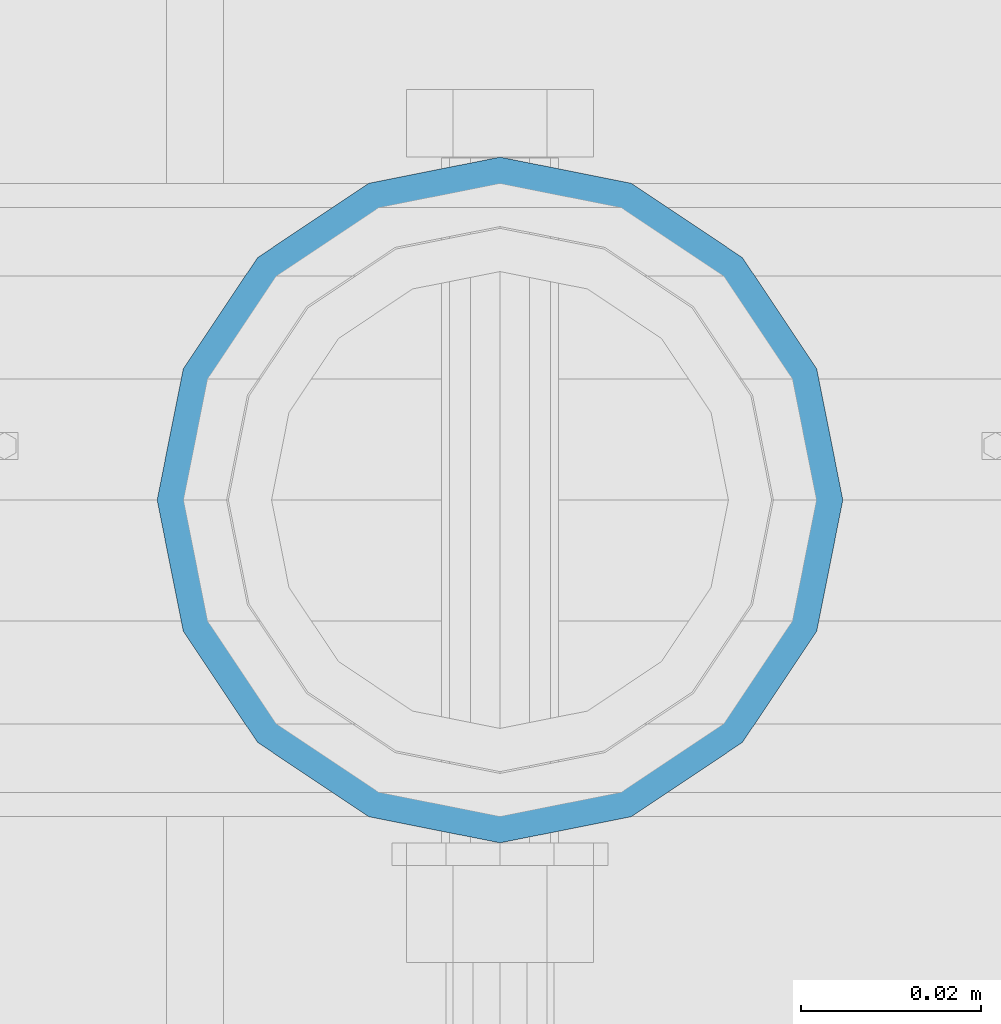
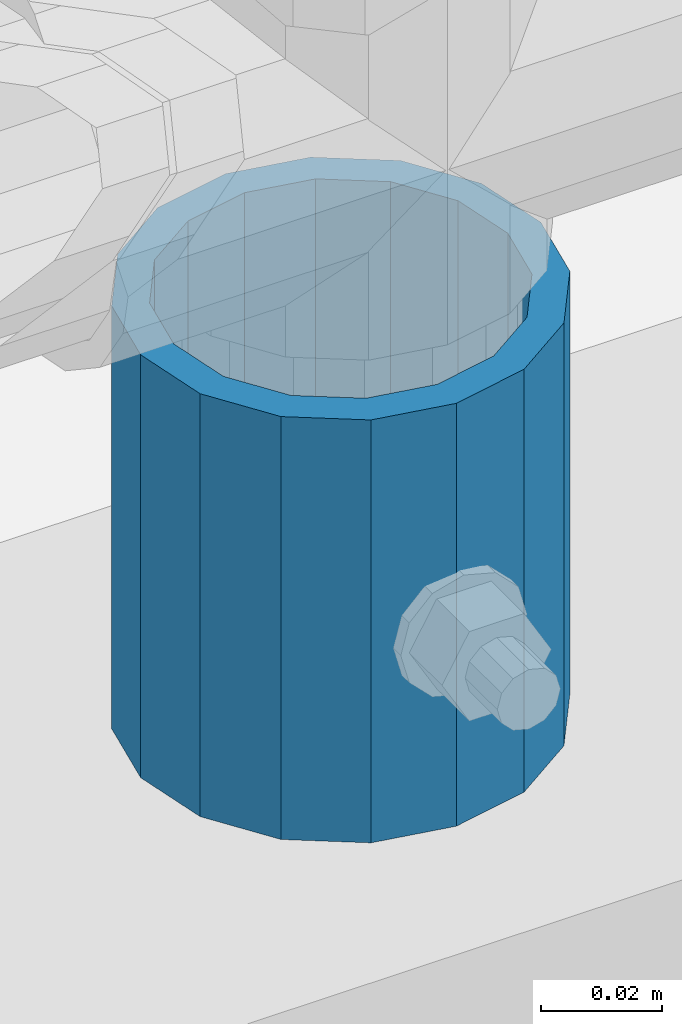
# One storey, part 69 of 242: 1 column.
"""IFC2X3 building model written with IfcOpenShell, lengths in millimetres."""

from ifc_helpers import new_model, si_unit, frame, origin_with_axes, place, context, subcontext, project, spatial, faceted_brep, material, type_object, element, save


model = new_model("IFC2X3")

# Units and contexts
model_context = context("Model", 3, precision=1e-05, world=origin_with_axes())
body_context = subcontext(model_context, "Body", "Model", "MODEL_VIEW")
ifc_project = project(units=[si_unit("LENGTHUNIT", "METRE", prefix="MILLI"), si_unit("AREAUNIT", "SQUARE_METRE"), si_unit("VOLUMEUNIT", "CUBIC_METRE"), si_unit("MASSUNIT", "GRAM", prefix="KILO"), si_unit("TIMEUNIT", "SECOND"), si_unit("PLANEANGLEUNIT", "RADIAN"), si_unit("SOLIDANGLEUNIT", "STERADIAN"), si_unit("THERMODYNAMICTEMPERATUREUNIT", "DEGREE_CELSIUS"), si_unit("LUMINOUSINTENSITYUNIT", "LUMEN")], contexts=[model_context])

# Site, building, storey
site_placement = place(None, origin_with_axes())
site = spatial("IfcSite", under=ifc_project, at=site_placement, CompositionType="ELEMENT")
building_placement = place(site_placement, origin_with_axes())
building = spatial("IfcBuilding", under=site, at=building_placement, Name="Standard", CompositionType="ELEMENT")
storey_placement = place(building_placement, origin_with_axes())
storey = spatial("IfcBuildingStorey", under=building, at=storey_placement, Name="Undefined", CompositionType="ELEMENT", Elevation=0.0)

# Column
ifc_material = material()
column_type = type_object("IfcColumnType", PredefinedType="NOTDEFINED")
column_placement = place(storey_placement, frame((-38563.0, -19335.5, 168.02), z_axis=(0.0, 1.0, 0.0), x_axis=(0.0, 0.0, 1.0)))
element("IfcColumn", 1, at=column_placement, inside=storey, type_object=column_type, material=ifc_material, context=body_context, shape_type="Brep", body=[
    faceted_brep([(0.0, -31.75, 0.0), (0.0, -29.3331751572332, 12.1501989775934), (85.0, -29.3331751572332, 12.1501989775934), (85.0, -31.75, 0.0), (0.0, -22.4506403026717, 22.4506403026717), (85.0, -22.4506403026717, 22.4506403026717), (0.0, -12.1501989775934, 29.3331751572332), (85.0, -12.1501989775934, 29.3331751572332), (0.0, 0.0, 31.75), (85.0, 0.0, 31.75), (0.0, 12.1501989775934, 29.3331751572332), (85.0, 12.1501989775934, 29.3331751572332), (0.0, 22.4506403026717, 22.4506403026717), (85.0, 22.4506403026717, 22.4506403026717), (0.0, 29.3331751572332, 12.1501989775934), (85.0, 29.3331751572332, 12.1501989775934), (0.0, 31.75, 0.0), (85.0, 31.75, 0.0), (0.0, 29.3331751572332, -12.1501989775934), (85.0, 29.3331751572332, -12.1501989775934), (0.0, 22.4506403026717, -22.4506403026717), (85.0, 22.4506403026717, -22.4506403026717), (0.0, 12.1501989775934, -29.3331751572332), (85.0, 12.1501989775934, -29.3331751572332), (0.0, 0.0, -31.75), (85.0, 0.0, -31.75), (0.0, -12.1501989775934, -29.3331751572332), (85.0, -12.1501989775934, -29.3331751572332), (0.0, -22.4506403026717, -22.4506403026717), (85.0, -22.4506403026717, -22.4506403026717), (0.0, -29.3331751572332, -12.1501989775934), (85.0, -29.3331751572332, -12.1501989775934), (0.0, -38.0499999999993, 0.0), (0.0, -35.1536162120537, -14.5611046014928), (85.0, -35.1536162120537, -14.5611046014928), (85.0, -38.0499999999993, 0.0), (0.0, -26.9054130241493, -26.9054130241493), (85.0, -26.9054130241493, -26.9054130241493), (0.0, -14.5611046014928, -35.1536162120537), (85.0, -14.5611046014928, -35.1536162120537), (0.0, 0.0, -38.0499999999993), (85.0, 0.0, -38.0499999999993), (0.0, 14.5611046014928, -35.1536162120537), (85.0, 14.5611046014928, -35.1536162120537), (0.0, 26.9054130241493, -26.9054130241493), (85.0, 26.9054130241493, -26.9054130241493), (0.0, 35.1536162120537, -14.5611046014928), (85.0, 35.1536162120537, -14.5611046014928), (0.0, 38.0499999999993, 0.0), (85.0, 38.0499999999993, 0.0), (0.0, 35.1536162120537, 14.5611046014928), (85.0, 35.1536162120537, 14.5611046014928), (0.0, 26.9054130241493, 26.9054130241493), (85.0, 26.9054130241493, 26.9054130241493), (0.0, 14.5611046014928, 35.1536162120537), (85.0, 14.5611046014928, 35.1536162120537), (0.0, 0.0, 38.0499999999993), (85.0, 0.0, 38.0499999999993), (0.0, -14.5611046014928, 35.1536162120537), (85.0, -14.5611046014928, 35.1536162120537), (0.0, -26.9054130241493, 26.9054130241493), (85.0, -26.9054130241493, 26.9054130241493), (0.0, -35.1536162120537, 14.5611046014928), (85.0, -35.1536162120537, 14.5611046014928)], [[[0, 1, 2, 3]], [[1, 4, 5, 2]], [[4, 6, 7, 5]], [[6, 8, 9, 7]], [[8, 10, 11, 9]], [[10, 12, 13, 11]], [[12, 14, 15, 13]], [[14, 16, 17, 15]], [[16, 18, 19, 17]], [[18, 20, 21, 19]], [[20, 22, 23, 21]], [[22, 24, 25, 23]], [[24, 26, 27, 25]], [[26, 28, 29, 27]], [[28, 30, 31, 29]], [[30, 0, 3, 31]], [[32, 33, 34, 35]], [[33, 36, 37, 34]], [[36, 38, 39, 37]], [[38, 40, 41, 39]], [[40, 42, 43, 41]], [[42, 44, 45, 43]], [[44, 46, 47, 45]], [[46, 48, 49, 47]], [[48, 50, 51, 49]], [[50, 52, 53, 51]], [[52, 54, 55, 53]], [[54, 56, 57, 55]], [[56, 58, 59, 57]], [[58, 60, 61, 59]], [[60, 62, 63, 61]], [[62, 32, 35, 63]], [[37, 39, 41, 43, 45, 47, 49, 51, 53, 55, 57, 59, 61, 63, 35, 34], [5, 7, 9, 11, 13, 15, 17, 19, 21, 23, 25, 27, 29, 31, 3, 2]], [[62, 60, 58, 56, 54, 52, 50, 48, 46, 44, 42, 40, 38, 36, 33, 32], [30, 28, 26, 24, 22, 20, 18, 16, 14, 12, 10, 8, 6, 4, 1, 0]]]),
])

save(model, "model.ifc")
